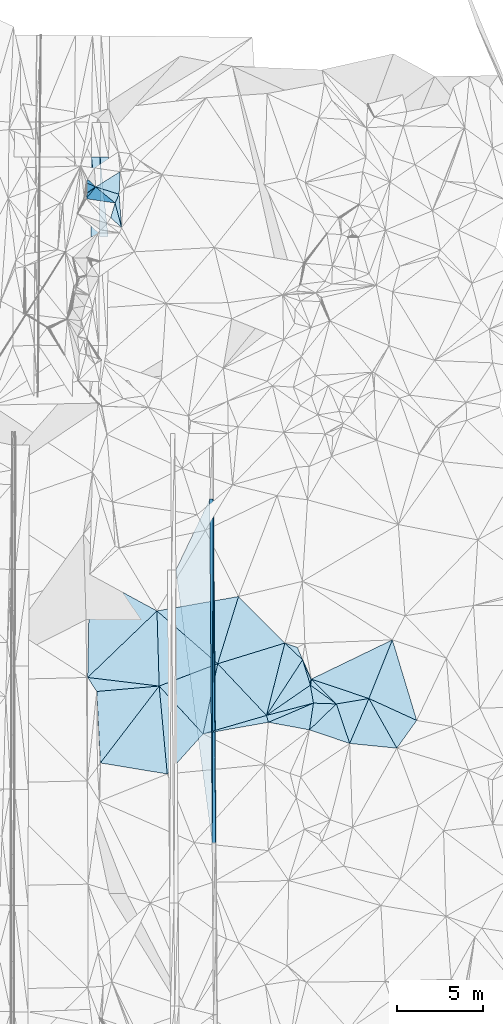
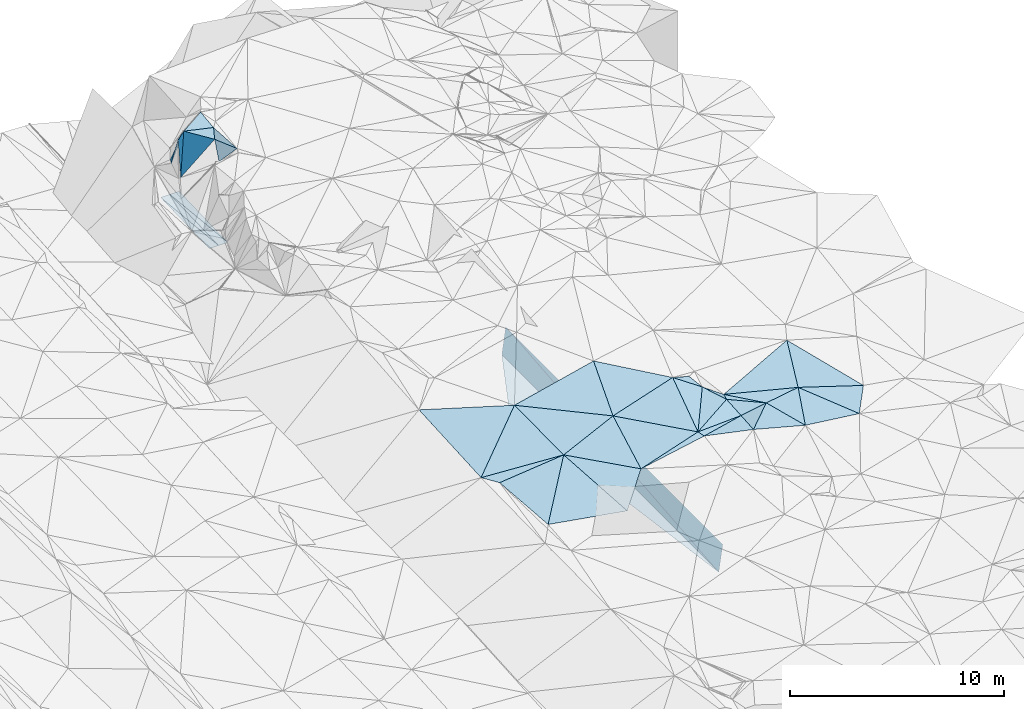
# One storey, part 153 of 275: 45 plates.
"""IFC2X3 building model written with IfcOpenShell, lengths in millimetres."""

from ifc_helpers import new_model, si_unit, frame, origin_with_axes, place, context, subcontext, project, spatial, polyline, outline, extrude, material, type_object, element, save


model = new_model("IFC2X3")

# Units and contexts
model_context = context("Model", 3, precision=1e-05, world=origin_with_axes())
body_context = subcontext(model_context, "Body", "Model", "MODEL_VIEW")
ifc_project = project(units=[si_unit("LENGTHUNIT", "METRE", prefix="MILLI"), si_unit("AREAUNIT", "SQUARE_METRE"), si_unit("VOLUMEUNIT", "CUBIC_METRE"), si_unit("MASSUNIT", "GRAM", prefix="KILO"), si_unit("TIMEUNIT", "SECOND"), si_unit("PLANEANGLEUNIT", "RADIAN"), si_unit("SOLIDANGLEUNIT", "STERADIAN"), si_unit("THERMODYNAMICTEMPERATUREUNIT", "DEGREE_CELSIUS"), si_unit("LUMINOUSINTENSITYUNIT", "LUMEN")], contexts=[model_context])

# Site, building, storey
site_placement = place(None, origin_with_axes())
site = spatial("IfcSite", under=ifc_project, at=site_placement, CompositionType="ELEMENT")
building_placement = place(site_placement, origin_with_axes())
building = spatial("IfcBuilding", under=site, at=building_placement, Name="Undefined", CompositionType="ELEMENT")
storey_placement = place(building_placement, origin_with_axes())
storey = spatial("IfcBuildingStorey", under=building, at=storey_placement, Name="Undefined", CompositionType="ELEMENT", Elevation=0.0)

# Plates
ifc_material = material()
plate_type_1 = type_object("IfcPlateType", PredefinedType="NOTDEFINED")
plate_1_placement = place(storey_placement, frame((-45826.8298291358, 112966.239027678, 45016.5042892505), z_axis=(0.989904776667533, 0.00941620352793395, -0.141420890401393), x_axis=(0.00717866799923532, -0.999840989554408, -0.0163236739926441)))
element("IfcPlate", 1, at=plate_1_placement, inside=storey, type_object=plate_type_1, material=ifc_material, Name="00_PR", context=body_context, shape_type="SweptSolid", body=[
    extrude(outline(polyline([(0.0, 0.0), (20002.666015625, 1.7214915715158e-08), (20027.150390625, 1515.03100585938), (0.0, 0.0)])), frame((-8.85201319254618e-08, 2.18876761149539e-07, -0.5000001331573), z_axis=(0.0, 0.0, 1.0), x_axis=(1.0, 0.0, 0.0)), (0.0, 0.0, 1.0), 1.0),
])
plate_2_placement = place(storey_placement, frame((-45897.5173910837, 92965.215779671, 43189.9872898601), z_axis=(0.989904776667533, 0.00941620352793395, -0.141420890401393), x_axis=(-0.00717871401283639, 0.999840989207004, 0.0163236750360178)))
element("IfcPlate", 2, at=plate_2_placement, inside=storey, type_object=plate_type_1, material=ifc_material, Name="00_PR", context=body_context, shape_type="SweptSolid", body=[
    extrude(outline(polyline([(0.0, 0.0), (20002.666015625, 1.7214915715158e-08), (20027.150390625, 1515.03112792969), (0.0, 0.0)])), frame((-8.85201319254618e-08, 2.18876761149539e-07, -0.5000001331573), z_axis=(0.0, 0.0, 1.0), x_axis=(1.0, 0.0, 0.0)), (0.0, 0.0, 1.0), 1.0),
])
plate_type_2 = type_object("IfcPlateType", PredefinedType="NOTDEFINED")
plate_3_placement = place(storey_placement, frame((-46041.6059999148, 112964.703958167, 43516.0750680092), z_axis=(-0.000489852644223191, 0.0163205775660144, -0.999866690510439), x_axis=(0.00717866799923532, -0.999840989554408, -0.0163236739926441)))
element("IfcPlate", 3, at=plate_3_placement, inside=storey, type_object=plate_type_2, material=ifc_material, Name="00_PR", context=body_context, shape_type="SweptSolid", body=[
    extrude(outline(polyline([(0.0, 0.0), (20002.666015625, 1.7214915715158e-08), (4107.9736328125, 2000.0), (0.0, 0.0)])), frame((-8.85201319254618e-08, 2.18876761149539e-07, -0.5000001331573), z_axis=(0.0, 0.0, 1.0), x_axis=(1.0, 0.0, 0.0)), (0.0, 0.0, 1.0), 1.0),
])
plate_type_3 = type_object("IfcPlateType", PredefinedType="NOTDEFINED")
plate_4_placement = place(storey_placement, frame((-35149.9327055757, 98476.59257565, 45119.5021839094), z_axis=(-0.0386793101629274, 0.0850564453316848, -0.995625086100616), x_axis=(-0.993971863007348, 0.0990150395029005, 0.0470739577892082)))
element("IfcPlate", 4, at=plate_4_placement, inside=storey, type_object=plate_type_3, material=ifc_material, Name="00", context=body_context, shape_type="SweptSolid", body=[
    extrude(outline(polyline([(0.0, 0.0), (2761.61181640625, -1.80443748831749e-09), (1917.82922363281, 2722.21069335938), (0.0, 0.0)])), frame((-8.85201319254618e-08, 2.18876761149539e-07, -0.5000001331573), z_axis=(0.0, 0.0, 1.0), x_axis=(1.0, 0.0, 0.0)), (0.0, 0.0, 1.0), 1.0),
])
plate_type_4 = type_object("IfcPlateType", PredefinedType="NOTDEFINED")
plate_5_placement = place(storey_placement, frame((-53234.730485025, 130455.314915956, 45499.9407644642), z_axis=(-0.567101078959767, 0.815081509387665, -0.118484173192004), x_axis=(0.0234372888424112, 0.159763917999654, 0.986876985240368)))
element("IfcPlate", 5, at=plate_5_placement, inside=storey, type_object=plate_type_4, material=ifc_material, Name="00", context=body_context, shape_type="SweptSolid", body=[
    extrude(outline(polyline([(0.0, 0.0), (1975.93017578125, -1.70257408171892e-09), (2125.98608398438, 620.631286621094), (0.0, 0.0)])), frame((-8.85201319254618e-08, 2.18876761149539e-07, -0.5000001331573), z_axis=(0.0, 0.0, 1.0), x_axis=(1.0, 0.0, 0.0)), (0.0, 0.0, 1.0), 1.0),
])
plate_type_5 = type_object("IfcPlateType", PredefinedType="NOTDEFINED")
plate_6_placement = place(storey_placement, frame((-40183.0139800067, 102144.867168921, 45469.532841087), z_axis=(-0.228839083585385, 0.273237760629245, -0.934330669511665), x_axis=(0.159748823185743, -0.936247109947189, -0.312924372023508)))
element("IfcPlate", 6, at=plate_6_placement, inside=storey, type_object=plate_type_5, material=ifc_material, Name="00", context=body_context, shape_type="SweptSolid", body=[
    extrude(outline(polyline([(0.0, 0.0), (1118.48107910156, 5.06042852066457e-09), (1208.69274902344, 2861.82836914063), (0.0, 0.0)])), frame((-8.85201319254618e-08, 2.18876761149539e-07, -0.5000001331573), z_axis=(0.0, 0.0, 1.0), x_axis=(1.0, 0.0, 0.0)), (0.0, 0.0, 1.0), 1.0),
])
plate_type_6 = type_object("IfcPlateType", PredefinedType="NOTDEFINED")
plate_7_placement = place(storey_placement, frame((-51921.2398166053, 132873.924464513, 42790.7261332549), z_axis=(0.000185105295013841, 0.0229268555143402, -0.999737127965274), x_axis=(-0.00781323691300057, -0.999706596155201, -0.0229276019836918)))
element("IfcPlate", 7, at=plate_7_placement, inside=storey, type_object=plate_type_6, material=ifc_material, Name="00_PR", context=body_context, shape_type="SweptSolid", body=[
    extrude(outline(polyline([(0.0, 0.0), (4612.2138671875, -4.30300133302808e-08), (3.44742345809937, 500.001403808594), (0.0, 0.0)])), frame((-8.85201319254618e-08, 2.18876761149539e-07, -0.5000001331573), z_axis=(0.0, 0.0, 1.0), x_axis=(1.0, 0.0, 0.0)), (0.0, 0.0, 1.0), 1.0),
])
plate_8_placement = place(storey_placement, frame((-52421.252882519, 132874.385777151, 42790.6441332998), z_axis=(0.000185042722302083, 0.0229252669820844, -0.999737164405221), x_axis=(-0.00781275090123706, -0.999706636394352, -0.0229260130080625)))
element("IfcPlate", 8, at=plate_8_placement, inside=storey, type_object=plate_type_6, material=ifc_material, Name="00_PR", context=body_context, shape_type="SweptSolid", body=[
    extrude(outline(polyline([(0.0, 0.0), (4611.3994140625, -3.00933606922627e-08), (3.44850325584412, 500.001892089844), (0.0, 0.0)])), frame((-8.85201319254618e-08, 2.18876761149539e-07, -0.5000001331573), z_axis=(0.0, 0.0, 1.0), x_axis=(1.0, 0.0, 0.0)), (0.0, 0.0, 1.0), 1.0),
])
plate_9_placement = place(storey_placement, frame((-52457.2806055018, 128264.3392322, 42684.9231333085), z_axis=(0.000170442319644708, 0.0229253810878847, -0.999737164384415), x_axis=(0.00781275088133285, 0.999706636394428, 0.0229260130115555)))
element("IfcPlate", 9, at=plate_9_placement, inside=storey, type_object=plate_type_6, material=ifc_material, Name="00_PR", context=body_context, shape_type="SweptSolid", body=[
    extrude(outline(polyline([(0.0, 0.0), (4611.3994140625, -3.00933606922627e-08), (2.63276791572571, 499.999145507813), (0.0, 0.0)])), frame((-8.85201319254618e-08, 2.18876761149539e-07, -0.5000001331573), z_axis=(0.0, 0.0, 1.0), x_axis=(1.0, 0.0, 0.0)), (0.0, 0.0, 1.0), 1.0),
])
plate_10_placement = place(storey_placement, frame((-52957.284555015, 128265.615851841, 42684.8671333431), z_axis=(0.000170498871511702, 0.0229238035927928, -0.999737200547711), x_axis=(0.00781204787958303, 0.999706678051832, 0.0229244360126394)))
element("IfcPlate", 10, at=plate_10_placement, inside=storey, type_object=plate_type_6, material=ifc_material, Name="00_PR", context=body_context, shape_type="SweptSolid", body=[
    extrude(outline(polyline([(0.0, 0.0), (4610.58251953125, -5.95537130720913e-08), (2.6310932636261, 499.998657226563), (0.0, 0.0)])), frame((-8.85201319254618e-08, 2.18876761149539e-07, -0.5000001331573), z_axis=(0.0, 0.0, 1.0), x_axis=(1.0, 0.0, 0.0)), (0.0, 0.0, 1.0), 1.0),
])
plate_type_7 = type_object("IfcPlateType", PredefinedType="NOTDEFINED")
plate_11_placement = place(storey_placement, frame((-51169.0567395024, 128776.618127937, 47449.7409484996), z_axis=(0.842421336981119, 0.147936313009174, -0.518113055512207), x_axis=(-0.521007081860968, 0.468843136993914, -0.713258532051615)))
element("IfcPlate", 11, at=plate_11_placement, inside=storey, type_object=plate_type_7, material=ifc_material, Name="00", context=body_context, shape_type="SweptSolid", body=[
    extrude(outline(polyline([(0.0, 0.0), (1219.75402832031, -6.22821971774101e-09), (1017.41821289063, 1092.4560546875), (0.0, 0.0)])), frame((-8.85201319254618e-08, 2.18876761149539e-07, -0.5000001331573), z_axis=(0.0, 0.0, 1.0), x_axis=(1.0, 0.0, 0.0)), (0.0, 0.0, 1.0), 1.0),
])
plate_type_8 = type_object("IfcPlateType", PredefinedType="NOTDEFINED")
plate_12_placement = place(storey_placement, frame((-40182.9114995296, 102144.716684084, 45469.5003414486), z_axis=(-0.0238814911813975, -0.0277302078102144, -0.999330130614381), x_axis=(-0.822451467004191, -0.567732180143974, 0.0354084178074089)))
element("IfcPlate", 12, at=plate_12_placement, inside=storey, type_object=plate_type_8, material=ifc_material, Name="00", context=body_context, shape_type="SweptSolid", body=[
    extrude(outline(polyline([(0.0, 0.0), (3106.60595703125, 2.75031197816134e-09), (-463.431823730469, 1469.50024414063), (0.0, 0.0)])), frame((-8.85201319254618e-08, 2.18876761149539e-07, -0.5000001331573), z_axis=(0.0, 0.0, 1.0), x_axis=(1.0, 0.0, 0.0)), (0.0, 0.0, 1.0), 1.0),
])
plate_type_9 = type_object("IfcPlateType", PredefinedType="NOTDEFINED")
plate_13_placement = place(storey_placement, frame((-52673.3503657853, 131139.80180395, 47529.8619906388), z_axis=(0.588704150716724, -0.759759404470541, -0.276030922629097), x_axis=(-0.805764403631107, -0.578831502833945, -0.125290930110695)))
element("IfcPlate", 13, at=plate_13_placement, inside=storey, type_object=plate_type_9, material=ifc_material, Name="00", context=body_context, shape_type="SweptSolid", body=[
    extrude(outline(polyline([(0.0, 0.0), (638.513916015625, -2.06637196242809e-09), (514.162658691406, 1800.28796386719), (0.0, 0.0)])), frame((-8.85201319254618e-08, 2.18876761149539e-07, -0.5000001331573), z_axis=(0.0, 0.0, 1.0), x_axis=(1.0, 0.0, 0.0)), (0.0, 0.0, 1.0), 1.0),
])
plate_type_10 = type_object("IfcPlateType", PredefinedType="NOTDEFINED")
plate_14_placement = place(storey_placement, frame((-44366.1274693668, 107303.837016597, 45989.5020207603), z_axis=(0.061981195016202, 0.0648009597646835, -0.995971469007993), x_axis=(-0.294607228784083, -0.952239550658949, -0.080289594026913)))
element("IfcPlate", 14, at=plate_14_placement, inside=storey, type_object=plate_type_10, material=ifc_material, Name="00", context=body_context, shape_type="SweptSolid", body=[
    extrude(outline(polyline([(0.0, 0.0), (4110.12158203125, -2.1420419216156e-08), (2226.50341796875, 4288.36572265625), (0.0, 0.0)])), frame((-8.85201319254618e-08, 2.18876761149539e-07, -0.5000001331573), z_axis=(0.0, 0.0, 1.0), x_axis=(1.0, 0.0, 0.0)), (0.0, 0.0, 1.0), 1.0),
])
plate_type_11 = type_object("IfcPlateType", PredefinedType="NOTDEFINED")
plate_15_placement = place(storey_placement, frame((-40234.6180244602, 99541.3937723974, 45349.5173993854), z_axis=(0.197051232344804, -0.171854076209213, -0.965213441846762), x_axis=(0.144984244886, 0.978799758918551, -0.144674118887323)))
element("IfcPlate", 15, at=plate_15_placement, inside=storey, type_object=plate_type_11, material=ifc_material, Name="00", context=body_context, shape_type="SweptSolid", body=[
    extrude(outline(polyline([(0.0, 0.0), (1589.77990722656, 2.47382558882236e-09), (1698.09680175781, 1357.59619140625), (0.0, 0.0)])), frame((-8.85201319254618e-08, 2.18876761149539e-07, -0.5000001331573), z_axis=(0.0, 0.0, 1.0), x_axis=(1.0, 0.0, 0.0)), (0.0, 0.0, 1.0), 1.0),
])
plate_type_12 = type_object("IfcPlateType", PredefinedType="NOTDEFINED")
plate_16_placement = place(storey_placement, frame((-51549.1148497173, 130204.908560818, 47239.6403001614), z_axis=(0.69020568039664, 0.0778455925628548, -0.719413776950893), x_axis=(0.374729329915466, 0.81204972207249, 0.447384821136231)))
element("IfcPlate", 16, at=plate_16_placement, inside=storey, type_object=plate_type_12, material=ifc_material, Name="00", context=body_context, shape_type="SweptSolid", body=[
    extrude(outline(polyline([(0.0, 0.0), (625.859436035156, 1.01863406598568e-09), (-923.530090332031, 1172.89904785156), (0.0, 0.0)])), frame((-8.85201319254618e-08, 2.18876761149539e-07, -0.5000001331573), z_axis=(0.0, 0.0, 1.0), x_axis=(1.0, 0.0, 0.0)), (0.0, 0.0, 1.0), 1.0),
])
plate_type_13 = type_object("IfcPlateType", PredefinedType="NOTDEFINED")
plate_17_placement = place(storey_placement, frame((-52673.5800941616, 131140.397719556, 47529.5537438687), z_axis=(0.129246350165869, 0.432079651377154, -0.89252594126703), x_axis=(0.953958331483799, -0.29985697708679, -0.00702104586357231)))
element("IfcPlate", 17, at=plate_17_placement, inside=storey, type_object=plate_type_13, material=ifc_material, Name="00", context=body_context, shape_type="SweptSolid", body=[
    extrude(outline(polyline([(0.0, 0.0), (1424.28930664063, 3.08500602841377e-09), (1354.92138671875, 622.003295898438), (0.0, 0.0)])), frame((-8.85201319254618e-08, 2.18876761149539e-07, -0.5000001331573), z_axis=(0.0, 0.0, 1.0), x_axis=(1.0, 0.0, 0.0)), (0.0, 0.0, 1.0), 1.0),
])
plate_type_14 = type_object("IfcPlateType", PredefinedType="NOTDEFINED")
plate_18_placement = place(storey_placement, frame((-53203.7423558484, 131375.673967046, 45749.8482910715), z_axis=(0.933802877382104, -0.189584097147861, -0.303430480178795), x_axis=(0.262613999851546, 0.93915615282708, 0.221403721036959)))
element("IfcPlate", 18, at=plate_18_placement, inside=storey, type_object=plate_type_14, material=ifc_material, Name="00", context=body_context, shape_type="SweptSolid", body=[
    extrude(outline(polyline([(0.0, 0.0), (225.831802368164, -1.77533365786076e-09), (312.179260253906, 1846.06176757813), (0.0, 0.0)])), frame((-8.85201319254618e-08, 2.18876761149539e-07, -0.5000001331573), z_axis=(0.0, 0.0, 1.0), x_axis=(1.0, 0.0, 0.0)), (0.0, 0.0, 1.0), 1.0),
])
plate_type_15 = type_object("IfcPlateType", PredefinedType="NOTDEFINED")
plate_19_placement = place(storey_placement, frame((-51314.9286547952, 130713.121181729, 47519.5005271365), z_axis=(0.00684239675861282, 0.0451584626356299, -0.99895640288202), x_axis=(-0.953958331476473, 0.299856977110532, 0.00702104584494157)))
element("IfcPlate", 19, at=plate_19_placement, inside=storey, type_object=plate_type_15, material=ifc_material, Name="00", context=body_context, shape_type="SweptSolid", body=[
    extrude(outline(polyline([(0.0, 0.0), (1424.28930664063, 3.08500602841377e-09), (335.95703125, 1277.197265625), (0.0, 0.0)])), frame((-8.85201319254618e-08, 2.18876761149539e-07, -0.5000001331573), z_axis=(0.0, 0.0, 1.0), x_axis=(1.0, 0.0, 0.0)), (0.0, 0.0, 1.0), 1.0),
])
plate_type_16 = type_object("IfcPlateType", PredefinedType="NOTDEFINED")
plate_20_placement = place(storey_placement, frame((-52673.3829475036, 131140.558136479, 47529.8006086029), z_axis=(0.523538714300432, 0.752908421790123, -0.398793333728333), x_axis=(0.754045010245231, -0.627358954125787, -0.194517004918513)))
element("IfcPlate", 20, at=plate_20_placement, inside=storey, type_object=plate_type_16, material=ifc_material, Name="00", context=body_context, shape_type="SweptSolid", body=[
    extrude(outline(polyline([(0.0, 0.0), (1490.87219238281, -5.10772224515677e-09), (401.912384033203, 2177.94995117188), (0.0, 0.0)])), frame((-8.85201319254618e-08, 2.18876761149539e-07, -0.5000001331573), z_axis=(0.0, 0.0, 1.0), x_axis=(1.0, 0.0, 0.0)), (0.0, 0.0, 1.0), 1.0),
])
plate_type_17 = type_object("IfcPlateType", PredefinedType="NOTDEFINED")
plate_21_placement = place(storey_placement, frame((-40130.4263824125, 102495.980300309, 45519.5018011328), z_axis=(0.00179181019010973, 0.0846346704115628, -0.996410438514455), x_axis=(0.947291588247815, -0.319362359942102, -0.0254230188440198)))
element("IfcPlate", 21, at=plate_21_placement, inside=storey, type_object=plate_type_17, material=ifc_material, Name="00", context=body_context, shape_type="SweptSolid", body=[
    extrude(outline(polyline([(0.0, 0.0), (3540.09887695313, 4.99130692332983e-09), (1845.48522949219, 905.088073730469), (0.0, 0.0)])), frame((-8.85201319254618e-08, 2.18876761149539e-07, -0.5000001331573), z_axis=(0.0, 0.0, 1.0), x_axis=(1.0, 0.0, 0.0)), (0.0, 0.0, 1.0), 1.0),
])
plate_type_18 = type_object("IfcPlateType", PredefinedType="NOTDEFINED")
plate_22_placement = place(storey_placement, frame((-35410.6733340634, 104779.350485304, 45569.500559569), z_axis=(-0.0114528898115635, 0.0455461959380598, -0.998896578906213), x_axis=(-0.371278324895024, -0.927741878072748, -0.0380448831407686)))
element("IfcPlate", 22, at=plate_22_placement, inside=storey, type_object=plate_type_18, material=ifc_material, Name="00", context=body_context, shape_type="SweptSolid", body=[
    extrude(outline(polyline([(0.0, 0.0), (3679.86401367188, 2.459273673594e-09), (3872.64306640625, 3534.84594726563), (0.0, 0.0)])), frame((-8.85201319254618e-08, 2.18876761149539e-07, -0.5000001331573), z_axis=(0.0, 0.0, 1.0), x_axis=(1.0, 0.0, 0.0)), (0.0, 0.0, 1.0), 1.0),
])
plate_type_19 = type_object("IfcPlateType", PredefinedType="NOTDEFINED")
plate_23_placement = place(storey_placement, frame((-53145.0443809698, 102590.649482677, 45277.5011547375), z_axis=(0.0616579357752637, 0.0290389258358592, -0.99767481663227), x_axis=(0.0198724463805357, 0.999342808424188, 0.0303156251083419)))
element("IfcPlate", 23, at=plate_23_placement, inside=storey, type_object=plate_type_19, material=ifc_material, Name="00", context=body_context, shape_type="SweptSolid", body=[
    extrude(outline(polyline([(0.0, 0.0), (6003.5048828125, 2.32539605349302e-08), (3961.22583007813, 3963.16552734375), (0.0, 0.0)])), frame((-8.85201319254618e-08, 2.18876761149539e-07, -0.5000001331573), z_axis=(0.0, 0.0, 1.0), x_axis=(1.0, 0.0, 0.0)), (0.0, 0.0, 1.0), 1.0),
])
plate_type_20 = type_object("IfcPlateType", PredefinedType="NOTDEFINED")
plate_24_placement = place(storey_placement, frame((-41669.6416270755, 104592.650256617, 45749.5018190261), z_axis=(-0.00321323168812661, 0.085005093839989, -0.996375335485264), x_axis=(-0.955523454716648, -0.294092738045898, -0.0220088372030275)))
element("IfcPlate", 24, at=plate_24_placement, inside=storey, type_object=plate_type_20, material=ifc_material, Name="00", context=body_context, shape_type="SweptSolid", body=[
    extrude(outline(polyline([(0.0, 0.0), (4089.26635742188, 4.97675500810146e-09), (1773.96118164063, 3395.94775390625), (0.0, 0.0)])), frame((-8.85201319254618e-08, 2.18876761149539e-07, -0.5000001331573), z_axis=(0.0, 0.0, 1.0), x_axis=(1.0, 0.0, 0.0)), (0.0, 0.0, 1.0), 1.0),
])
plate_type_21 = type_object("IfcPlateType", PredefinedType="NOTDEFINED")
plate_25_placement = place(storey_placement, frame((-40636.8756652741, 103617.050501268, 45439.5389233821), z_axis=(0.0806138006009897, 0.378298614840431, -0.922166781641193), x_axis=(-0.710166051196644, 0.670984635959273, 0.213175509931059)))
element("IfcPlate", 25, at=plate_25_placement, inside=storey, type_object=plate_type_21, material=ifc_material, Name="00", context=body_context, shape_type="SweptSolid", body=[
    extrude(outline(polyline([(0.0, 0.0), (1454.20080566406, 6.89760781824589e-09), (752.647094726563, 339.444213867188), (0.0, 0.0)])), frame((-8.85201319254618e-08, 2.18876761149539e-07, -0.5000001331573), z_axis=(0.0, 0.0, 1.0), x_axis=(1.0, 0.0, 0.0)), (0.0, 0.0, 1.0), 1.0),
])
plate_type_22 = type_object("IfcPlateType", PredefinedType="NOTDEFINED")
plate_26_placement = place(storey_placement, frame((-41669.7429910862, 104592.653534743, 45749.5128709878), z_axis=(-0.205941349719995, 0.0915642144898226, -0.974271089122719), x_axis=(0.710166051197326, -0.670984635958439, -0.213175509931415)))
element("IfcPlate", 26, at=plate_26_placement, inside=storey, type_object=plate_type_22, material=ifc_material, Name="00", context=body_context, shape_type="SweptSolid", body=[
    extrude(outline(polyline([(0.0, 0.0), (1454.20080566406, 6.89760781824589e-09), (2103.4921875, 3805.65649414063), (0.0, 0.0)])), frame((-8.85201319254618e-08, 2.18876761149539e-07, -0.5000001331573), z_axis=(0.0, 0.0, 1.0), x_axis=(1.0, 0.0, 0.0)), (0.0, 0.0, 1.0), 1.0),
])
plate_type_23 = type_object("IfcPlateType", PredefinedType="NOTDEFINED")
plate_27_placement = place(storey_placement, frame((-40636.7490864917, 103616.903252961, 45439.5305454798), z_axis=(0.333770504720789, 0.083803444680826, -0.938921845969119), x_axis=(0.41089768513722, -0.909368409034599, 0.0649013790204603)))
element("IfcPlate", 27, at=plate_27_placement, inside=storey, type_object=plate_type_23, material=ifc_material, Name="00", context=body_context, shape_type="SweptSolid", body=[
    extrude(outline(polyline([(0.0, 0.0), (1232.63940429688, 6.83940015733242e-10), (1527.21057128906, 204.518569946289), (0.0, 0.0)])), frame((-8.85201319254618e-08, 2.18876761149539e-07, -0.5000001331573), z_axis=(0.0, 0.0, 1.0), x_axis=(1.0, 0.0, 0.0)), (0.0, 0.0, 1.0), 1.0),
])
plate_type_24 = type_object("IfcPlateType", PredefinedType="NOTDEFINED")
plate_28_placement = place(storey_placement, frame((-36776.9101798202, 101365.423229777, 45429.5036959566), z_axis=(0.0224327427698763, 0.119153136891199, -0.992622436790952), x_axis=(0.908885253151803, -0.416008919939153, -0.0293968558564092)))
element("IfcPlate", 28, at=plate_28_placement, inside=storey, type_object=plate_type_24, material=ifc_material, Name="00", context=body_context, shape_type="SweptSolid", body=[
    extrude(outline(polyline([(0.0, 0.0), (3061.55200195313, -6.27187546342611e-09), (2689.64892578125, 1963.23413085938), (0.0, 0.0)])), frame((-8.85201319254618e-08, 2.18876761149539e-07, -0.5000001331573), z_axis=(0.0, 0.0, 1.0), x_axis=(1.0, 0.0, 0.0)), (0.0, 0.0, 1.0), 1.0),
])
plate_type_25 = type_object("IfcPlateType", PredefinedType="NOTDEFINED")
plate_29_placement = place(storey_placement, frame((-33994.3277578194, 100091.753530054, 45339.500559285), z_axis=(-0.0114597990901014, 0.0455489520057079, -0.998896373992816), x_axis=(-0.908885253151602, 0.416008919939339, 0.0293968558599931)))
element("IfcPlate", 29, at=plate_29_placement, inside=storey, type_object=plate_type_25, material=ifc_material, Name="00", context=body_context, shape_type="SweptSolid", body=[
    extrude(outline(polyline([(0.0, 0.0), (3061.55200195313, -6.27187546342611e-09), (3244.13891601563, 3675.33154296875), (0.0, 0.0)])), frame((-8.85201319254618e-08, 2.18876761149539e-07, -0.5000001331573), z_axis=(0.0, 0.0, 1.0), x_axis=(1.0, 0.0, 0.0)), (0.0, 0.0, 1.0), 1.0),
])
plate_type_26 = type_object("IfcPlateType", PredefinedType="NOTDEFINED")
plate_30_placement = place(storey_placement, frame((-38672.0734211092, 101052.466753082, 45399.5413177029), z_axis=(0.204438658170214, 0.341500394137083, -0.917377956923851), x_axis=(-0.978073047039923, 0.0332326098874546, -0.205593551197765)))
element("IfcPlate", 30, at=plate_30_placement, inside=storey, type_object=plate_type_26, material=ifc_material, Name="00", context=body_context, shape_type="SweptSolid", body=[
    extrude(outline(polyline([(0.0, 0.0), (1361.91040039063, -2.6338966563344e-09), (1499.51123046875, 1109.98474121094), (0.0, 0.0)])), frame((-8.85201319254618e-08, 2.18876761149539e-07, -0.5000001331573), z_axis=(0.0, 0.0, 1.0), x_axis=(1.0, 0.0, 0.0)), (0.0, 0.0, 1.0), 1.0),
])
plate_type_27 = type_object("IfcPlateType", PredefinedType="NOTDEFINED")
plate_31_placement = place(storey_placement, frame((-37894.8753202965, 98750.0243971827, 45249.5011232473), z_axis=(0.00478849160943962, 0.0666232739467043, -0.997766711068639), x_axis=(-0.319270693205932, 0.945658622156305, 0.061611645013277)))
element("IfcPlate", 31, at=plate_31_placement, inside=storey, type_object=plate_type_27, material=ifc_material, Name="00", context=body_context, shape_type="SweptSolid", body=[
    extrude(outline(polyline([(0.0, 0.0), (2434.60473632813, 1.12358975457028e-08), (2127.40893554688, 1896.4521484375), (0.0, 0.0)])), frame((-8.85201319254618e-08, 2.18876761149539e-07, -0.5000001331573), z_axis=(0.0, 0.0, 1.0), x_axis=(1.0, 0.0, 0.0)), (0.0, 0.0, 1.0), 1.0),
])
plate_type_28 = type_object("IfcPlateType", PredefinedType="NOTDEFINED")
plate_32_placement = place(storey_placement, frame((-40004.2766839404, 101097.490862497, 45119.5071056666), z_axis=(-0.106331748832774, -0.129958668651876, -0.985801350999478), x_axis=(-0.144984244881897, -0.978799758918626, 0.144674118890925)))
element("IfcPlate", 32, at=plate_32_placement, inside=storey, type_object=plate_type_28, material=ifc_material, Name="00", context=body_context, shape_type="SweptSolid", body=[
    extrude(outline(polyline([(0.0, 0.0), (1589.77990722656, 2.47382558882236e-09), (1534.61499023438, 2440.0732421875), (0.0, 0.0)])), frame((-8.85201319254618e-08, 2.18876761149539e-07, -0.5000001331573), z_axis=(0.0, 0.0, 1.0), x_axis=(1.0, 0.0, 0.0)), (0.0, 0.0, 1.0), 1.0),
])
plate_type_29 = type_object("IfcPlateType", PredefinedType="NOTDEFINED")
plate_33_placement = place(storey_placement, frame((-42627.1139280884, 99981.7739125305, 45549.5076752016), z_axis=(-0.172520572718334, 0.0260652294131813, -0.984660985215001), x_axis=(-0.266949158058215, 0.961001445665229, 0.0722105839981242)))
element("IfcPlate", 33, at=plate_33_placement, inside=storey, type_object=plate_type_29, material=ifc_material, Name="00", context=body_context, shape_type="SweptSolid", body=[
    extrude(outline(polyline([(0.0, 0.0), (415.451568603516, 1.56796886585653e-09), (341.074645996094, 2862.28369140625), (0.0, 0.0)])), frame((-8.85201319254618e-08, 2.18876761149539e-07, -0.5000001331573), z_axis=(0.0, 0.0, 1.0), x_axis=(1.0, 0.0, 0.0)), (0.0, 0.0, 1.0), 1.0),
])
plate_type_30 = type_object("IfcPlateType", PredefinedType="NOTDEFINED")
plate_34_placement = place(storey_placement, frame((-42737.9263632608, 100381.029138927, 45579.5003888243), z_axis=(0.0114993766477733, 0.0374169236809724, -0.99923357537613), x_axis=(-0.686148853223281, 0.727204192038007, 0.0193342779210004)))
element("IfcPlate", 34, at=plate_34_placement, inside=storey, type_object=plate_type_30, material=ifc_material, Name="00", context=body_context, shape_type="SweptSolid", body=[
    extrude(outline(polyline([(0.0, 0.0), (4137.72900390625, -1.49811967276037e-08), (2332.970703125, 3669.46142578125), (0.0, 0.0)])), frame((-8.85201319254618e-08, 2.18876761149539e-07, -0.5000001331573), z_axis=(0.0, 0.0, 1.0), x_axis=(1.0, 0.0, 0.0)), (0.0, 0.0, 1.0), 1.0),
])
plate_type_31 = type_object("IfcPlateType", PredefinedType="NOTDEFINED")
plate_35_placement = place(storey_placement, frame((-42737.9222086188, 100381.050622833, 45579.5017218075), z_axis=(0.0198080415624964, 0.0803853390198687, -0.996567026727314), x_axis=(0.266949158060934, -0.961001445664689, -0.0722105839952564)))
element("IfcPlate", 35, at=plate_35_placement, inside=storey, type_object=plate_type_31, material=ifc_material, Name="00", context=body_context, shape_type="SweptSolid", body=[
    extrude(outline(polyline([(0.0, 0.0), (415.451568603516, 1.56796886585653e-09), (58.4905738830566, 3846.8662109375), (0.0, 0.0)])), frame((-8.85201319254618e-08, 2.18876761149539e-07, -0.5000001331573), z_axis=(0.0, 0.0, 1.0), x_axis=(1.0, 0.0, 0.0)), (0.0, 0.0, 1.0), 1.0),
])
plate_type_32 = type_object("IfcPlateType", PredefinedType="NOTDEFINED")
plate_36_placement = place(storey_placement, frame((-46428.7866819311, 99306.9374157928, 45419.5008977726), z_axis=(0.0278908742874284, 0.052855871765356, -0.998212580541543), x_axis=(0.203876748889743, 0.977309716278015, 0.057445537082824)))
element("IfcPlate", 36, at=plate_36_placement, inside=storey, type_object=plate_type_32, material=ifc_material, Name="00", context=body_context, shape_type="SweptSolid", body=[
    extrude(outline(polyline([(0.0, 0.0), (4177.8701171875, -2.37341737374663e-08), (1811.4013671875, 3394.20458984375), (0.0, 0.0)])), frame((-8.85201319254618e-08, 2.18876761149539e-07, -0.5000001331573), z_axis=(0.0, 0.0, 1.0), x_axis=(1.0, 0.0, 0.0)), (0.0, 0.0, 1.0), 1.0),
])
plate_type_33 = type_object("IfcPlateType", PredefinedType="NOTDEFINED")
plate_37_placement = place(storey_placement, frame((-38672.1873055155, 101052.324585509, 45399.5009588253), z_axis=(-0.0233233892507887, 0.0571534710886493, -0.998092931673386), x_axis=(0.319270693216557, -0.945658622154105, -0.0616116449919903)))
element("IfcPlate", 37, at=plate_37_placement, inside=storey, type_object=plate_type_33, material=ifc_material, Name="00", context=body_context, shape_type="SweptSolid", body=[
    extrude(outline(polyline([(0.0, 0.0), (2434.60473632813, 1.12358975457028e-08), (932.923522949219, 1963.73461914063), (0.0, 0.0)])), frame((-8.85201319254618e-08, 2.18876761149539e-07, -0.5000001331573), z_axis=(0.0, 0.0, 1.0), x_axis=(1.0, 0.0, 0.0)), (0.0, 0.0, 1.0), 1.0),
])
plate_type_34 = type_object("IfcPlateType", PredefinedType="NOTDEFINED")
plate_38_placement = place(storey_placement, frame((-46428.7745866179, 99306.9348709505, 45419.50125418), z_axis=(0.0520836051120259, 0.0477671176870417, -0.997499674459299), x_axis=(-0.675907708905776, 0.736986274663066, -8.74761918598289e-11)))
element("IfcPlate", 38, at=plate_38_placement, inside=storey, type_object=plate_type_34, material=ifc_material, Name="00", context=body_context, shape_type="SweptSolid", body=[
    extrude(outline(polyline([(0.0, 0.0), (3778.95483398438, 1.01790647022426e-08), (2433.45068359375, 3396.01513671875), (0.0, 0.0)])), frame((-8.85201319254618e-08, 2.18876761149539e-07, -0.5000001331573), z_axis=(0.0, 0.0, 1.0), x_axis=(1.0, 0.0, 0.0)), (0.0, 0.0, 1.0), 1.0),
])
plate_type_35 = type_object("IfcPlateType", PredefinedType="NOTDEFINED")
plate_39_placement = place(storey_placement, frame((-48982.9959420619, 102091.975980246, 45419.5015888837), z_axis=(0.0589961693285871, 0.0541067954248031, -0.996790803876827), x_axis=(0.675907709264868, -0.736986274333735, 9.03142150324425e-11)))
element("IfcPlate", 39, at=plate_39_placement, inside=storey, type_object=plate_type_35, material=ifc_material, Name="00", context=body_context, shape_type="SweptSolid", body=[
    extrude(outline(polyline([(0.0, 0.0), (3778.95483398438, 1.01790647022426e-08), (4088.48486328125, 3123.02587890625), (0.0, 0.0)])), frame((-8.85201319254618e-08, 2.18876761149539e-07, -0.5000001331573), z_axis=(0.0, 0.0, 1.0), x_axis=(1.0, 0.0, 0.0)), (0.0, 0.0, 1.0), 1.0),
])
plate_type_36 = type_object("IfcPlateType", PredefinedType="NOTDEFINED")
plate_40_placement = place(storey_placement, frame((-48983.0087129334, 102091.946294924, 45419.500279712), z_axis=(0.0334709875216657, -0.00523490840772734, -0.999425979614442), x_axis=(-0.995704394974809, -0.0865494516280454, -0.0328930121869954)))
element("IfcPlate", 40, at=plate_40_placement, inside=storey, type_object=plate_type_36, material=ifc_material, Name="00", context=body_context, shape_type="SweptSolid", body=[
    extrude(outline(polyline([(0.0, 0.0), (3648.19140625, 2.77941580861807e-09), (4105.68115234375, 857.259094238281), (0.0, 0.0)])), frame((-8.85201319254618e-08, 2.18876761149539e-07, -0.5000001331573), z_axis=(0.0, 0.0, 1.0), x_axis=(1.0, 0.0, 0.0)), (0.0, 0.0, 1.0), 1.0),
])
plate_type_37 = type_object("IfcPlateType", PredefinedType="NOTDEFINED")
plate_41_placement = place(storey_placement, frame((-38672.1504432167, 101052.362733401, 45399.5051059484), z_axis=(0.0505700722678656, 0.133355199134467, -0.98977727729759), x_axis=(-0.809763221419276, 0.585555908530257, 0.0375207039110657)))
element("IfcPlate", 41, at=plate_41_placement, inside=storey, type_object=plate_type_37, material=ifc_material, Name="00", context=body_context, shape_type="SweptSolid", body=[
    extrude(outline(polyline([(0.0, 0.0), (1865.63659667969, -1.12195266410708e-08), (2030.67407226563, 318.374969482422), (0.0, 0.0)])), frame((-8.85201319254618e-08, 2.18876761149539e-07, -0.5000001331573), z_axis=(0.0, 0.0, 1.0), x_axis=(1.0, 0.0, 0.0)), (0.0, 0.0, 1.0), 1.0),
])
plate_type_38 = type_object("IfcPlateType", PredefinedType="NOTDEFINED")
plate_42_placement = place(storey_placement, frame((-52615.5284226777, 101776.192428847, 45299.5003351801), z_axis=(0.0343225181657051, -0.0150803139366073, -0.999297027353899), x_axis=(0.995704394974157, 0.0865494516419387, 0.0328930121701748)))
element("IfcPlate", 42, at=plate_42_placement, inside=storey, type_object=plate_type_38, material=ifc_material, Name="00", context=body_context, shape_type="SweptSolid", body=[
    extrude(outline(polyline([(0.0, 0.0), (3648.19140625, 2.77941580861807e-09), (-148.539352416992, 4163.53662109375), (0.0, 0.0)])), frame((-8.85201319254618e-08, 2.18876761149539e-07, -0.5000001331573), z_axis=(0.0, 0.0, 1.0), x_axis=(1.0, 0.0, 0.0)), (0.0, 0.0, 1.0), 1.0),
])
plate_type_39 = type_object("IfcPlateType", PredefinedType="NOTDEFINED")
plate_43_placement = place(storey_placement, frame((-48513.8498377591, 96974.710913551, 45169.5009758722), z_axis=(-0.0439214992112921, 0.0447310459669915, -0.998033083336285), x_axis=(-0.985429514220319, 0.162369475395637, 0.0506441108447097)))
element("IfcPlate", 43, at=plate_43_placement, inside=storey, type_object=plate_type_39, material=ifc_material, Name="00", context=body_context, shape_type="SweptSolid", body=[
    extrude(outline(polyline([(0.0, 0.0), (3949.12646484375, 1.3882527127862e-08), (1305.90905761719, 4976.30419921875), (0.0, 0.0)])), frame((-8.85201319254618e-08, 2.18876761149539e-07, -0.5000001331573), z_axis=(0.0, 0.0, 1.0), x_axis=(1.0, 0.0, 0.0)), (0.0, 0.0, 1.0), 1.0),
])
plate_type_40 = type_object("IfcPlateType", PredefinedType="NOTDEFINED")
plate_44_placement = place(storey_placement, frame((-48983.0001563642, 102091.974755196, 45419.5013020042), z_axis=(0.0505829260520283, 0.0516830280689307, -0.997381688322801), x_axis=(-0.0293439736439572, 0.998305865248369, 0.0502427170989791)))
element("IfcPlate", 44, at=plate_44_placement, inside=storey, type_object=plate_type_40, material=ifc_material, Name="00", context=body_context, shape_type="SweptSolid", body=[
    extrude(outline(polyline([(0.0, 0.0), (4378.744140625, 2.73284967988729e-08), (1207.94909667969, 3447.3408203125), (0.0, 0.0)])), frame((-8.85201319254618e-08, 2.18876761149539e-07, -0.5000001331573), z_axis=(0.0, 0.0, 1.0), x_axis=(1.0, 0.0, 0.0)), (0.0, 0.0, 1.0), 1.0),
])
plate_type_41 = type_object("IfcPlateType", PredefinedType="NOTDEFINED")
plate_45_placement = place(storey_placement, frame((-49111.4950978909, 106463.300544496, 45639.5010588287), z_axis=(0.0402039890433713, 0.0514024493027781, -0.997868441965511), x_axis=(0.0293439736535003, -0.998305865248081, -0.0502427170991334)))
element("IfcPlate", 45, at=plate_45_placement, inside=storey, type_object=plate_type_41, material=ifc_material, Name="00", context=body_context, shape_type="SweptSolid", body=[
    extrude(outline(polyline([(0.0, 0.0), (4378.744140625, 2.73284967988729e-08), (3765.90625, 4149.20947265625), (0.0, 0.0)])), frame((-8.85201319254618e-08, 2.18876761149539e-07, -0.5000001331573), z_axis=(0.0, 0.0, 1.0), x_axis=(1.0, 0.0, 0.0)), (0.0, 0.0, 1.0), 1.0),
])

save(model, "model.ifc")
